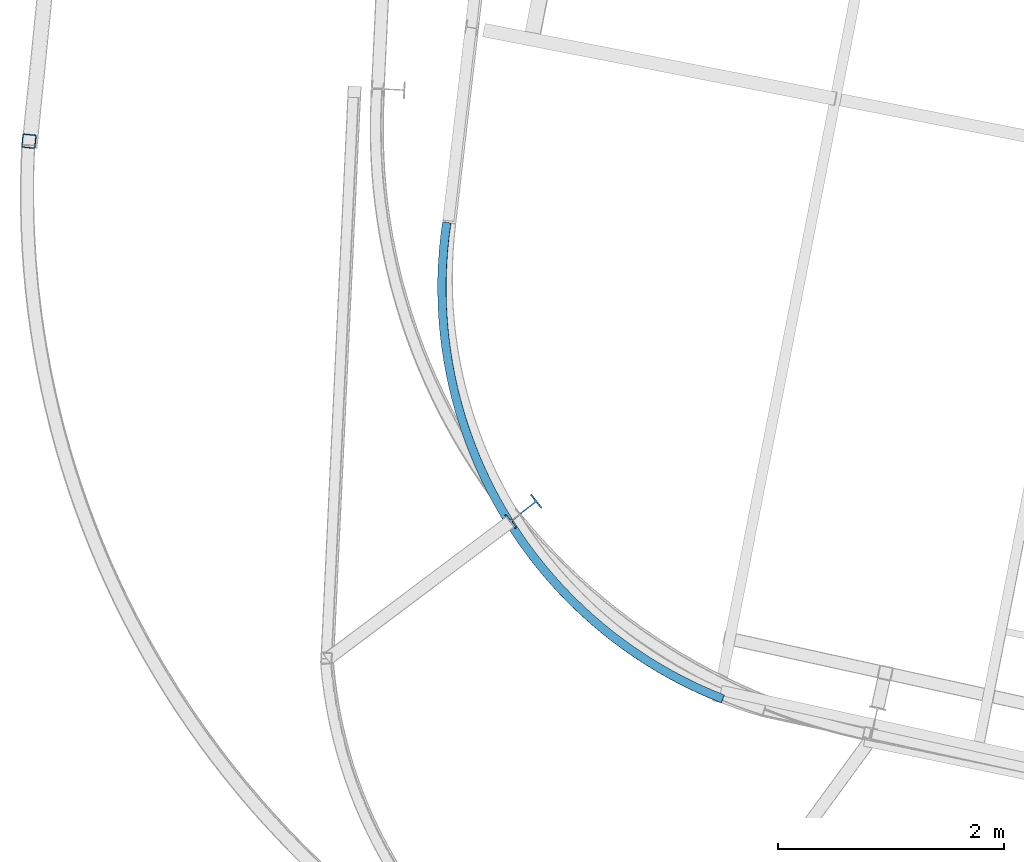
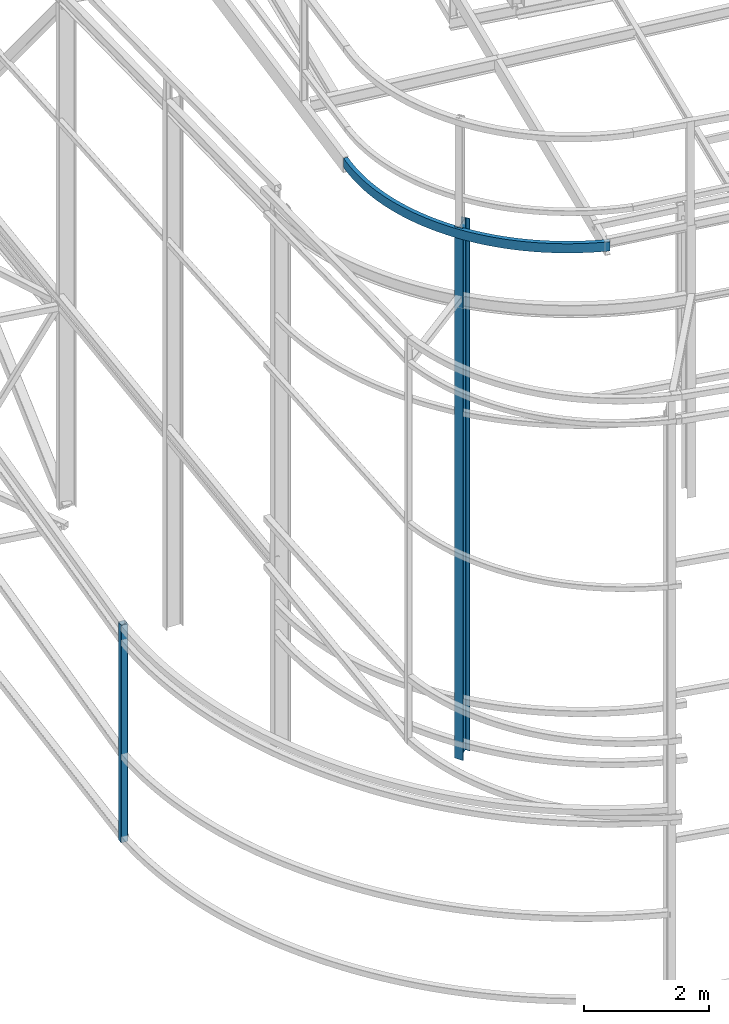
# One storey, part 19 of 215: 3 beams, 3 elements without a shape of their own.
"""IFC2X3 building model written with IfcOpenShell, lengths in millimetres."""

from ifc_helpers import new_model, entity, si_unit, frame, origin_with_axes, origin_2d_with_axis, place, context, subcontext, project, spatial, hollow_rectangle, i_section, extrude, clip, halfspace, material, type_object, element, aggregate, save


model = new_model("IFC2X3")

# Units and contexts
model_context = context("Model", 3, precision=1e-05, world=origin_with_axes())
body_context = subcontext(model_context, "Body", "Model", "MODEL_VIEW")
ifc_project = project(units=[si_unit("LENGTHUNIT", "METRE", prefix="MILLI"), si_unit("AREAUNIT", "SQUARE_METRE"), si_unit("VOLUMEUNIT", "CUBIC_METRE"), si_unit("MASSUNIT", "GRAM", prefix="KILO"), si_unit("TIMEUNIT", "SECOND"), si_unit("PLANEANGLEUNIT", "RADIAN"), si_unit("SOLIDANGLEUNIT", "STERADIAN"), si_unit("THERMODYNAMICTEMPERATUREUNIT", "DEGREE_CELSIUS"), si_unit("LUMINOUSINTENSITYUNIT", "LUMEN")], contexts=[model_context])

# Site, building, storey
site_placement = place(None, origin_with_axes())
site = spatial("IfcSite", under=ifc_project, at=site_placement, CompositionType="ELEMENT")
building_placement = place(site_placement, origin_with_axes())
building = spatial("IfcBuilding", under=site, at=building_placement, Name="Undefined", CompositionType="ELEMENT")
storey_placement = place(building_placement, origin_with_axes())
storey = spatial("IfcBuildingStorey", under=building, at=storey_placement, Name="Undefined", CompositionType="ELEMENT", Elevation=0.0)

# Assembly, beam
assembly_1_placement = place(storey_placement, origin_with_axes())
assembly_1 = element("IfcElementAssembly", 1, at=assembly_1_placement, inside=storey, Name="Steel Assembly", AssemblyPlace="NOTDEFINED", PredefinedType="RIGID_FRAME")
ifc_material = material(Name="STEEL/S275JR")
beam_type_1 = type_object("IfcBeamType", PredefinedType="NOTDEFINED")
beam_1_placement = place(assembly_1_placement, frame((34154.6781046658, 16104.043863428, 3802.30048835819), z_axis=(-0.994980121457876, 0.100072763046052, 0.0), x_axis=(0.0, 0.0, -1.0)))
beam_1 = element("IfcBeam", 2, at=beam_1_placement, type_object=beam_type_1, material=ifc_material, Name="MONTANT", context=body_context, shape_type="SweptSolid", body=[
    extrude(hollow_rectangle(XDim=120.0, YDim=120.0, WallThickness=5.0, InnerFilletRadius=5.0, OuterFilletRadius=10.0, at=origin_2d_with_axis()), frame((4252.26254436339, 0.0, 0.0), z_axis=(-1.0, 0.0, 0.0), x_axis=(-6.93889390390723e-18, -1.0, -3.46944695195361e-18)), (0.0, 0.0, 1.0), 4252.3),
])
aggregate(assembly_1, [beam_1])

assembly_2_placement = place(storey_placement, origin_with_axes())
assembly_2 = element("IfcElementAssembly", 3, at=assembly_2_placement, inside=storey, Name="Steel Assembly", AssemblyPlace="NOTDEFINED", PredefinedType="RIGID_FRAME")
beam_type_2 = type_object("IfcBeamType", Name="UPE180", PredefinedType="NOTDEFINED")
beam_2_placement = place(assembly_2_placement, frame((40301.0695677802, 11162.345607628, 12034.4299964036), z_axis=(-0.00870964100004953, 0.015032743000083, 0.999849068005538), x_axis=(-0.501239667283012, 0.865134067488474, -0.0173735780098094)))
beam_2 = element("IfcBeam", 4, at=beam_2_placement, type_object=beam_type_2, material=ifc_material, Name="POUTRE", ObjectType="UPE180", context=body_context, shape_type="SweptSolid", body=[
    entity("IfcRevolvedAreaSolid", entity("IfcUShapeProfileDef", "AREA", None, entity("IfcAxis2Placement2D", entity("IfcCartesianPoint", [0.0, 0.0]), entity("IfcDirection", [1.0, 0.0])), 180.0, 75.0, 5.5, 10.5, 12.0), entity("IfcAxis2Placement3D", entity("IfcCartesianPoint", [4878.61788870318, 7.69588478580585e-12, -3.63797880709171e-12]), entity("IfcDirection", [-0.781850826145721, 0.623465544882197, -6.20546042038153e-19]), entity("IfcDirection", [-0.623465544882197, -0.78185082614572, 7.78189652357871e-19])), entity("IfcAxis1Placement", entity("IfcCartesianPoint", [3912.5, 0.0, 0.0]), entity("IfcDirection", [0.0, 1.0, 0.0])), 1.34633480063108),
])
aggregate(assembly_2, [beam_2])

assembly_3_placement = place(storey_placement, origin_with_axes())
assembly_3 = element("IfcElementAssembly", 5, at=assembly_3_placement, inside=storey, Name="Steel Assembly", AssemblyPlace="NOTDEFINED", PredefinedType="RIGID_FRAME")
beam_type_3 = type_object("IfcBeamType", Name="IPE300", PredefinedType="NOTDEFINED")
beam_3_placement = place(assembly_3_placement, frame((38534.5673003165, 12824.1661047509, 12089.7087062039), z_axis=(0.784786213805784, 0.619766567846623, 0.0), x_axis=(0.0, 0.0, -1.0)))
beam_3 = element("IfcBeam", 6, at=beam_3_placement, type_object=beam_type_3, material=ifc_material, Name="MONTANT", ObjectType="IPE300", context=body_context, shape_type="Clipping", body=[
    clip(extrude(i_section(OverallWidth=150.0, OverallDepth=300.0, WebThickness=7.099999905, FlangeThickness=10.69999981, FilletRadius=15.0, at=origin_2d_with_axis()), frame((10413.4460951765, -3.63797880709171e-12, 0.0), z_axis=(-1.0, 0.0, 0.0), x_axis=(-6.93889390390723e-18, -1.0, -3.46944695195361e-18)), (0.0, 0.0, 1.0), 10413.4), halfspace(frame((10395.980487092, 94.3490162637772, -124.627592095625), z_axis=(0.99476982487221, 0.102142036026864, 1.79224939912546e-09), x_axis=(0.0, 0.0, 1.0)), False)),
])
aggregate(assembly_3, [beam_3])

save(model, "model.ifc")
